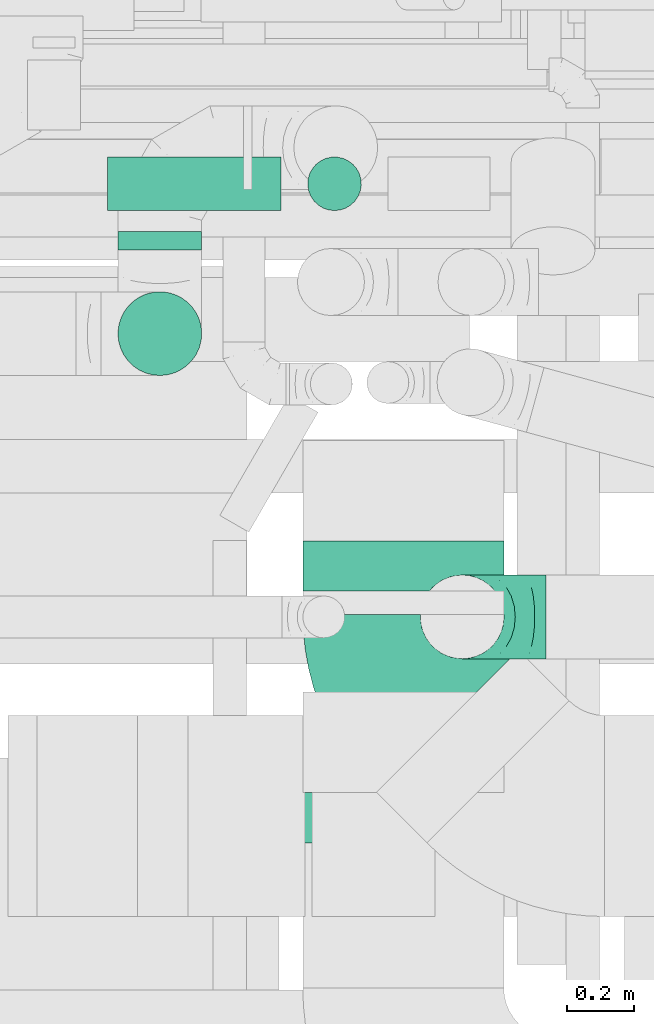
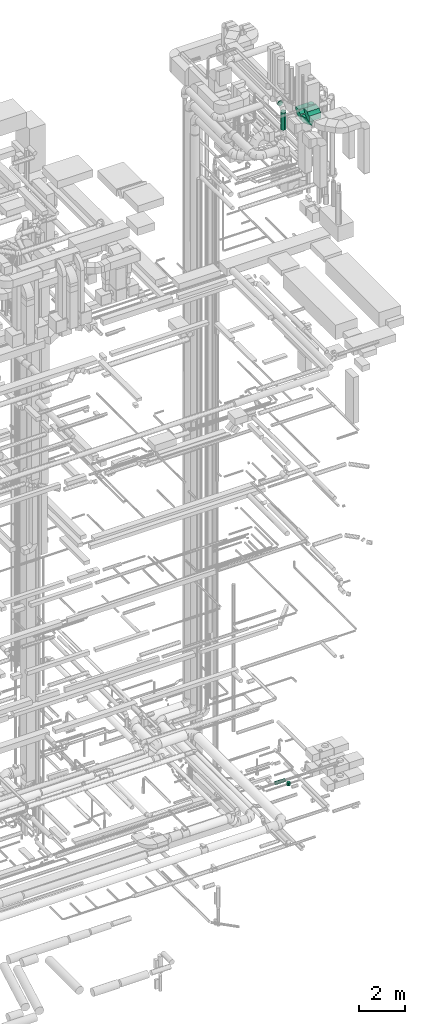
# One storey, part 298 of 337: 4 flow fittings, 4 flow segments.
"""IFC2X3 building model written with IfcOpenShell, lengths in millimetres."""

from ifc_helpers import new_model, entity, si_unit, converted_unit, derived_unit, direction, frame, frame_2d, origin, origin_2d_with_axis, place, context, subcontext, project, spatial, polyline, circle_curve, parameter, trimmed, segment, composite_curve, circle, outline, extrude, faceted_brep, source, transform, mapped, material, type_object, type_shapes, element, save


model = new_model("IFC2X3")

# Units and contexts
model_context = context("Model", 3, precision=0.01, world=origin(), true_north=direction((6.12303176911189e-17, 1.0)))
body_context = subcontext(model_context, "Body", "Model", "MODEL_VIEW")
ifc_project = project(units=[si_unit("LENGTHUNIT", "METRE", prefix="MILLI"), si_unit("AREAUNIT", "SQUARE_METRE"), si_unit("VOLUMEUNIT", "CUBIC_METRE"), converted_unit("PLANEANGLEUNIT", "DEGREE", entity("IfcRatioMeasure", 0.0174532925199433), si_unit("PLANEANGLEUNIT", "RADIAN"), dimensions=[0, 0, 0, 0, 0, 0, 0]), si_unit("MASSUNIT", "GRAM", prefix="KILO"), derived_unit("MASSDENSITYUNIT", [(si_unit("MASSUNIT", "GRAM", prefix="KILO"), 1), (si_unit("LENGTHUNIT", "METRE"), -3)]), derived_unit("MOMENTOFINERTIAUNIT", [(si_unit("LENGTHUNIT", "METRE"), 4)]), si_unit("TIMEUNIT", "SECOND"), si_unit("FREQUENCYUNIT", "HERTZ"), si_unit("THERMODYNAMICTEMPERATUREUNIT", "DEGREE_CELSIUS"), derived_unit("THERMALTRANSMITTANCEUNIT", [(si_unit("MASSUNIT", "GRAM", prefix="KILO"), 1), (si_unit("THERMODYNAMICTEMPERATUREUNIT", "KELVIN"), -1), (si_unit("TIMEUNIT", "SECOND"), -3)]), derived_unit("VOLUMETRICFLOWRATEUNIT", [(si_unit("LENGTHUNIT", "METRE"), 3), (si_unit("TIMEUNIT", "SECOND"), -1)]), derived_unit("MASSFLOWRATEUNIT", [(si_unit("MASSUNIT", "GRAM", prefix="KILO"), 1), (si_unit("TIMEUNIT", "SECOND"), -1)]), derived_unit("ROTATIONALFREQUENCYUNIT", [(si_unit("TIMEUNIT", "SECOND"), -1)]), si_unit("ELECTRICCURRENTUNIT", "AMPERE"), si_unit("ELECTRICVOLTAGEUNIT", "VOLT"), si_unit("POWERUNIT", "WATT"), si_unit("FORCEUNIT", "NEWTON", prefix="KILO"), si_unit("ILLUMINANCEUNIT", "LUX"), si_unit("LUMINOUSFLUXUNIT", "LUMEN"), si_unit("LUMINOUSINTENSITYUNIT", "CANDELA"), derived_unit("USERDEFINED", [(si_unit("MASSUNIT", "GRAM", prefix="KILO"), -1), (si_unit("LENGTHUNIT", "METRE"), -2), (si_unit("TIMEUNIT", "SECOND"), 3), (si_unit("LUMINOUSFLUXUNIT", "LUMEN"), 1)]), derived_unit("LINEARVELOCITYUNIT", [(si_unit("LENGTHUNIT", "METRE"), 1), (si_unit("TIMEUNIT", "SECOND"), -1)]), si_unit("PRESSUREUNIT", "PASCAL"), derived_unit("USERDEFINED", [(si_unit("LENGTHUNIT", "METRE"), -2), (si_unit("MASSUNIT", "GRAM", prefix="KILO"), 1), (si_unit("TIMEUNIT", "SECOND"), -2)]), derived_unit("LINEARFORCEUNIT", [(si_unit("MASSUNIT", "GRAM", prefix="KILO"), 1), (si_unit("LENGTHUNIT", "METRE"), 1), (si_unit("TIMEUNIT", "SECOND"), -2), (si_unit("LENGTHUNIT", "METRE"), -1)]), derived_unit("PLANARFORCEUNIT", [(si_unit("MASSUNIT", "GRAM", prefix="KILO"), 1), (si_unit("LENGTHUNIT", "METRE"), 1), (si_unit("TIMEUNIT", "SECOND"), -2), (si_unit("LENGTHUNIT", "METRE"), -2)])], contexts=[model_context])

# Site, building, storey
site_placement = place(None, origin())
site = spatial("IfcSite", under=ifc_project, at=site_placement, CompositionType="ELEMENT")
building_placement = place(site_placement, origin())
building = spatial("IfcBuilding", under=site, at=building_placement, CompositionType="ELEMENT")
storey_placement = place(building_placement, origin())
storey = spatial("IfcBuildingStorey", under=building, at=storey_placement, CompositionType="ELEMENT", Elevation=0.0)

# Flow segments
duct_segment_type = type_object("IfcDuctSegmentType", PredefinedType="NOTDEFINED")
flow_segment_1_placement = place(storey_placement, frame((70337.23, 9559.41, -631.6)))
element("IfcFlowSegment", 1, at=flow_segment_1_placement, inside=storey, type_object=duct_segment_type, context=body_context, shape_type="SweptSolid", body=[
    extrude(circle(Radius=80.0, at=origin_2d_with_axis()), frame((0.0, 81.6, 81.6), z_axis=(1.0, 0.0, 0.0), x_axis=(0.0, -1.0, 0.0)), (0.0, 0.0, 1.0), 517.221330000017),
])
flow_segment_2_placement = place(storey_placement, frame((70932.86, 9559.41, -890.0)))
element("IfcFlowSegment", 2, at=flow_segment_2_placement, inside=storey, type_object=duct_segment_type, context=body_context, shape_type="SweptSolid", body=[
    extrude(circle(Radius=80.0, at=origin_2d_with_axis()), frame((81.6, 81.6, 0.0), z_axis=(0.0, 0.0, 1.0), x_axis=(0.0, -1.0, 0.0)), (0.0, 0.0, 1.0), 179.999999997708),
])
flow_segment_3_placement = place(storey_placement, frame((70366.5, 9067.1, 34375.0)))
element("IfcFlowSegment", 3, at=flow_segment_3_placement, inside=storey, type_object=duct_segment_type, context=body_context, shape_type="SweptSolid", body=[
    extrude(circle(Radius=125.0, at=origin_2d_with_axis()), frame((126.6, 126.6, 0.0), z_axis=(0.0, 0.0, 1.0), x_axis=(0.0, -1.0, 0.0)), (0.0, 0.0, 1.0), 924.999999999993),
])
flow_segment_4_placement = place(storey_placement, frame((70366.5, 9443.7, 35423.4)))
element("IfcFlowSegment", 4, at=flow_segment_4_placement, inside=storey, type_object=duct_segment_type, context=body_context, shape_type="SweptSolid", body=[
    extrude(circle(Radius=125.0, at=origin_2d_with_axis()), frame((126.6, 0.0, 126.6), z_axis=(0.0, 1.0, 0.0), x_axis=(1.0, 0.0, 0.0)), (0.0, 0.0, 1.0), 54.9999999999171),
])

# Flow fittings
ifc_material = material()
duct_fitting_type_1 = type_object("IfcDuctFittingType", PredefinedType="NOTDEFINED", material=ifc_material)
shared_shape_1 = source(origin(), body_context, "Body", "Brep", [
    faceted_brep([(-250.0, 0.0, -125.0), (-250.0, -32.35, -120.74), (-250.0, -62.5, -108.25), (-250.0, -88.39, -88.39), (-250.0, -108.25, -62.5), (-250.0, -120.74, -32.35), (-250.0, -125.0, 0.0), (-250.0, -120.74, 32.35), (-250.0, -108.25, 62.5), (-250.0, -88.39, 88.39), (-250.0, -62.5, 108.25), (-250.0, -32.35, 120.74), (-250.0, 0.0, 125.0), (-250.0, 32.35, 120.74), (-250.0, 62.5, 108.25), (-250.0, 88.39, 88.39), (-250.0, 108.25, 62.5), (-250.0, 120.74, 32.35), (-250.0, 125.0, 0.0), (-250.0, 120.74, -32.35), (-250.0, 108.25, -62.5), (-250.0, 88.39, -88.39), (-250.0, 62.5, -108.25), (-250.0, 32.35, -120.74), (-191.68, 32.35, 120.74), (-199.76, 62.5, 108.25), (-183.01, 0.0, 125.0), (-206.7, 88.39, 88.39), (-215.37, 120.74, 32.35), (-216.51, 125.0, 0.0), (-212.02, 108.25, 62.5), (-212.02, 108.25, -62.5), (-206.7, 88.39, -88.39), (-215.37, 120.74, -32.35), (-191.68, 32.35, -120.74), (-183.01, 0.0, -125.0), (-199.76, 62.5, -108.25), (-174.34, -32.35, -120.74), (-166.27, -62.5, -108.25), (-159.33, -88.39, -88.39), (-154.01, -108.25, -62.5), (-150.66, -120.74, -32.35), (-149.52, -125.0, 0.0), (-150.66, -120.74, 32.35), (-154.01, -108.25, 62.5), (-159.33, -88.39, 88.39), (-166.27, -62.5, 108.25), (-174.34, -32.35, 120.74), (-90.67, 90.67, 120.74), (-112.74, 112.74, 108.25), (-66.99, 66.99, 125.0), (-131.69, 131.69, 88.39), (-146.23, 146.23, 62.5), (-155.38, 155.38, 32.35), (-158.49, 158.49, 0.0), (-155.38, 155.38, -32.35), (-146.23, 146.23, -62.5), (-131.69, 131.69, -88.39), (-90.67, 90.67, -120.74), (-66.99, 66.99, -125.0), (-112.74, 112.74, -108.25), (-43.3, 43.3, -120.74), (-21.23, 21.23, -108.25), (-2.28, 2.28, -88.39), (12.26, -12.26, -62.5), (21.4, -21.4, -32.35), (24.52, -24.52, 0.0), (21.4, -21.4, 32.35), (12.26, -12.26, 62.5), (-2.28, 2.28, 88.39), (-21.23, 21.23, 108.25), (-43.3, 43.3, 120.74), (-32.35, 191.68, 120.74), (-62.5, 199.76, 108.25), (0.0, 183.01, 125.0), (-88.39, 206.7, 88.39), (-108.25, 212.02, 62.5), (-120.74, 215.37, 32.35), (-125.0, 216.51, 0.0), (-120.74, 215.37, -32.35), (-108.25, 212.02, -62.5), (-88.39, 206.7, -88.39), (-32.35, 191.68, -120.74), (0.0, 183.01, -125.0), (-62.5, 199.76, -108.25), (32.35, 174.34, -120.74), (62.5, 166.27, -108.25), (88.39, 159.33, -88.39), (108.25, 154.01, -62.5), (120.74, 150.66, -32.35), (125.0, 149.52, 0.0), (120.74, 150.66, 32.35), (108.25, 154.01, 62.5), (88.39, 159.33, 88.39), (62.5, 166.27, 108.25), (32.35, 174.34, 120.74), (-32.35, 250.0, -120.74), (-62.5, 250.0, -108.25), (-88.39, 250.0, -88.39), (-108.25, 250.0, -62.5), (-120.74, 250.0, -32.35), (-125.0, 250.0, 0.0), (-120.74, 250.0, 32.35), (-108.25, 250.0, 62.5), (-88.39, 250.0, 88.39), (-62.5, 250.0, 108.25), (-32.35, 250.0, 120.74), (0.0, 250.0, 125.0), (32.35, 250.0, 120.74), (62.5, 250.0, 108.25), (88.39, 250.0, 88.39), (108.25, 250.0, 62.5), (120.74, 250.0, 32.35), (125.0, 250.0, 0.0), (120.74, 250.0, -32.35), (108.25, 250.0, -62.5), (88.39, 250.0, -88.39), (62.5, 250.0, -108.25), (32.35, 250.0, -120.74), (0.0, 250.0, -125.0)], [[[0, 1, 2, 3, 4, 5, 6, 7, 8, 9, 10, 11, 12, 13, 14, 15, 16, 17, 18, 19, 20, 21, 22, 23]], [[24, 25, 14, 13]], [[26, 24, 13, 12]], [[14, 25, 27, 15]], [[28, 29, 18, 17]], [[30, 28, 17, 16]], [[15, 27, 30, 16]], [[20, 31, 32, 21]], [[33, 31, 20, 19]], [[18, 29, 33, 19]], [[34, 35, 0, 23]], [[36, 34, 23, 22]], [[21, 32, 36, 22]], [[1, 0, 35, 37]], [[2, 1, 37, 38]], [[38, 39, 3, 2]], [[5, 4, 40, 41]], [[6, 5, 41, 42]], [[39, 40, 4, 3]], [[6, 42, 43, 7]], [[7, 43, 44, 8]], [[8, 44, 45, 9]], [[9, 45, 46, 10]], [[10, 46, 47, 11]], [[26, 12, 11, 47]], [[48, 49, 25, 24]], [[50, 48, 24, 26]], [[27, 25, 49, 51]], [[52, 53, 28, 30]], [[51, 52, 30, 27]], [[29, 28, 53, 54]], [[55, 56, 31, 33]], [[54, 55, 33, 29]], [[32, 31, 56, 57]], [[58, 59, 35, 34]], [[60, 58, 34, 36]], [[57, 60, 36, 32]], [[37, 35, 59, 61]], [[38, 37, 61, 62]], [[39, 38, 62, 63]], [[41, 40, 64, 65]], [[42, 41, 65, 66]], [[63, 64, 40, 39]], [[43, 42, 66, 67]], [[44, 43, 67, 68]], [[68, 69, 45, 44]], [[46, 45, 69, 70]], [[47, 46, 70, 71]], [[26, 47, 71, 50]], [[72, 73, 49, 48]], [[74, 72, 48, 50]], [[51, 49, 73, 75]], [[76, 77, 53, 52]], [[75, 76, 52, 51]], [[54, 53, 77, 78]], [[79, 80, 56, 55]], [[78, 79, 55, 54]], [[57, 56, 80, 81]], [[82, 83, 59, 58]], [[84, 82, 58, 60]], [[81, 84, 60, 57]], [[61, 59, 83, 85]], [[62, 61, 85, 86]], [[63, 62, 86, 87]], [[65, 64, 88, 89]], [[66, 65, 89, 90]], [[87, 88, 64, 63]], [[67, 66, 90, 91]], [[68, 67, 91, 92]], [[92, 93, 69, 68]], [[70, 69, 93, 94]], [[71, 70, 94, 95]], [[50, 71, 95, 74]], [[96, 97, 98, 99, 100, 101, 102, 103, 104, 105, 106, 107, 108, 109, 110, 111, 112, 113, 114, 115, 116, 117, 118, 119]], [[72, 74, 107, 106]], [[73, 72, 106, 105]], [[75, 73, 105, 104]], [[77, 76, 103, 102]], [[78, 77, 102, 101]], [[75, 104, 103, 76]], [[78, 101, 100, 79]], [[79, 100, 99, 80]], [[80, 99, 98, 81]], [[84, 97, 96, 82]], [[82, 96, 119, 83]], [[84, 81, 98, 97]], [[83, 119, 118, 85]], [[85, 118, 117, 86]], [[116, 87, 86, 117]], [[88, 115, 114, 89]], [[89, 114, 113, 90]], [[115, 88, 87, 116]], [[91, 90, 113, 112]], [[92, 91, 112, 111]], [[111, 110, 93, 92]], [[95, 94, 109, 108]], [[74, 95, 108, 107]], [[110, 109, 94, 93]]]),
])
type_shapes(duct_fitting_type_1, [shared_shape_1])
flow_fitting_1_placement = place(storey_placement, frame((71395.58, 8348.12, 35675.0), z_axis=(0.0, 1.0, 0.0), x_axis=(-1.0, 0.0, 0.0)))
element("IfcFlowFitting", 5, at=flow_fitting_1_placement, inside=storey, type_object=duct_fitting_type_1, material=ifc_material, context=body_context, shape_type="MappedRepresentation", body=[
    mapped(shared_shape_1, transform((0.0, 0.0, 0.0), scale=1.0)),
])
duct_fitting_type_2 = type_object("IfcDuctFittingType", PredefinedType="NOTDEFINED", material=ifc_material)
shared_shape_2 = source(origin(), body_context, "Body", "SweptSolid", [
    extrude(outline(composite_curve([segment(polyline([(-365.9, -159.1), (234.1, -159.1)]), True, "CONTINUOUS"), segment(trimmed(circle_curve(frame_2d((384.1, -159.1), x_axis=(-0.707106781186553, 0.707106781186546)), 150.0), [parameter(0.0)], [parameter(45.0)], True, "PARAMETER"), False, "CONTINUOUS"), segment(polyline([(278.03, -53.03), (-146.23, 371.23)]), True, "CONTINUOUS"), segment(trimmed(circle_curve(frame_2d((384.1, -159.1), x_axis=(-0.707106781186553, 0.707106781186546)), 750.0), [parameter(0.0)], [parameter(45.0)], True, "PARAMETER"), True, "CONTINUOUS")], self_intersect=False)), frame((-27.3, 65.9, -150.0), z_axis=(0.0, 0.0, 1.0), x_axis=(-0.707106781186547, 0.707106781186548, 0.0)), (0.0, 0.0, 1.0), 300.0),
])
type_shapes(duct_fitting_type_2, [shared_shape_2])
flow_fitting_2_placement = place(storey_placement, frame((71219.75, 8168.4, 35300.0), z_axis=(0.0, 0.0, 1.0), x_axis=(0.0, -1.0, 0.0)))
element("IfcFlowFitting", 6, at=flow_fitting_2_placement, inside=storey, type_object=duct_fitting_type_2, material=ifc_material, context=body_context, shape_type="MappedRepresentation", body=[
    mapped(shared_shape_2, transform((0.0, 0.0, 0.0), scale=1.0)),
])
duct_fitting_type_3 = type_object("IfcDuctFittingType", PredefinedType="NOTDEFINED", material=ifc_material)
shared_shape_3 = source(origin(), body_context, "Body", "SweptSolid", [
    extrude(outline(composite_curve([segment(polyline([(-300.0, -150.0), (0.0, -150.0)]), True, "CONTINUOUS"), segment(trimmed(circle_curve(frame_2d((150.0, -150.0), x_axis=(0.0, 1.0)), 150.0), [parameter(0.0)], [parameter(90.0)], True, "PARAMETER"), False, "CONTINUOUS"), segment(polyline([(150.0, 0.0), (150.0, 300.0)]), True, "CONTINUOUS"), segment(trimmed(circle_curve(frame_2d((150.0, -150.0), x_axis=(0.0, 1.0)), 450.0), [parameter(0.0)], [parameter(90.0000000000001)], True, "PARAMETER"), True, "CONTINUOUS")], self_intersect=False)), frame((-150.0, 150.0, -300.0), z_axis=(0.0, 0.0, 1.0), x_axis=(-1.0, 0.0, 0.0)), (0.0, 0.0, 1.0), 600.0),
])
type_shapes(duct_fitting_type_3, [shared_shape_3])
for number, where, z_axis, x_axis in (
    (7, (71219.75, 7973.58, 35650.0), (1.0, 0.0, 0.0), (0.0, 1.0, 0.0)),
    (8, (71219.75, 8724.98, 35300.0), (1.0, 0.0, 0.0), (0.0, 1.0, 0.0)),
):
    element("IfcFlowFitting", number, at=place(storey_placement, frame(where, z_axis=z_axis, x_axis=x_axis)), inside=storey, type_object=duct_fitting_type_3, material=ifc_material, context=body_context, shape_type="MappedRepresentation", body=[
        mapped(shared_shape_3, transform((0.0, 0.0, 0.0), scale=1.0)),
    ])

save(model, "model.ifc")
